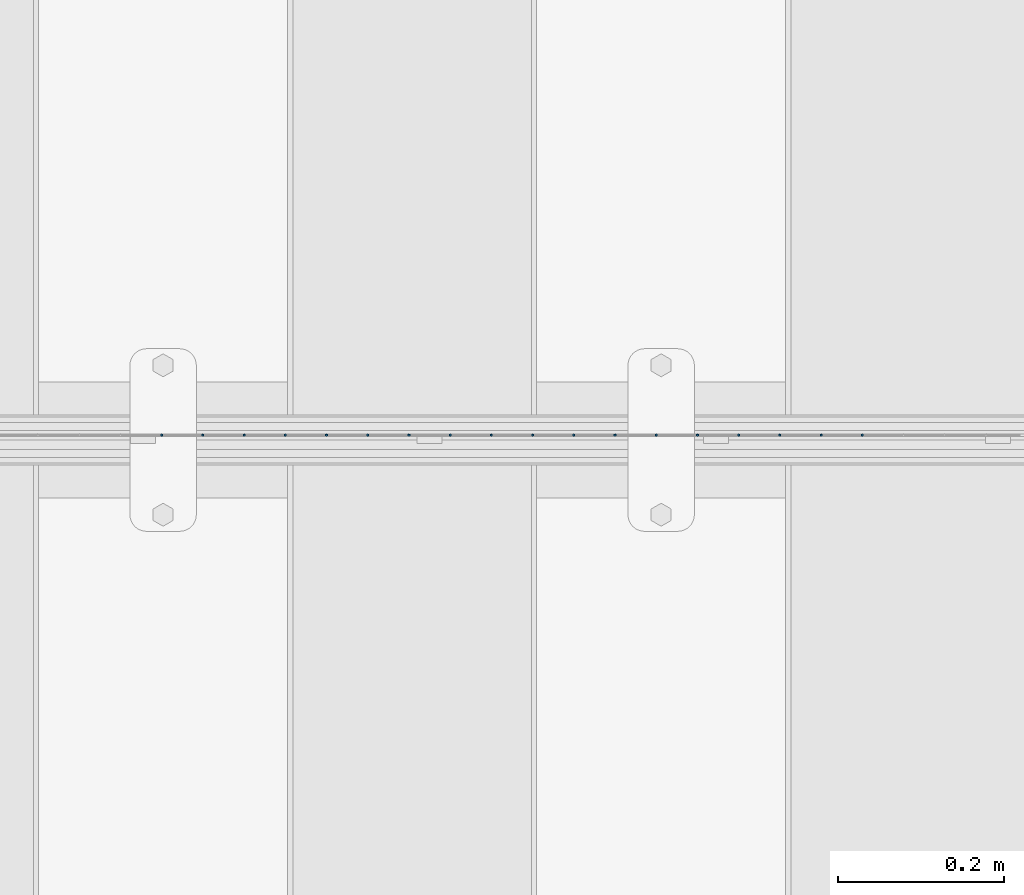
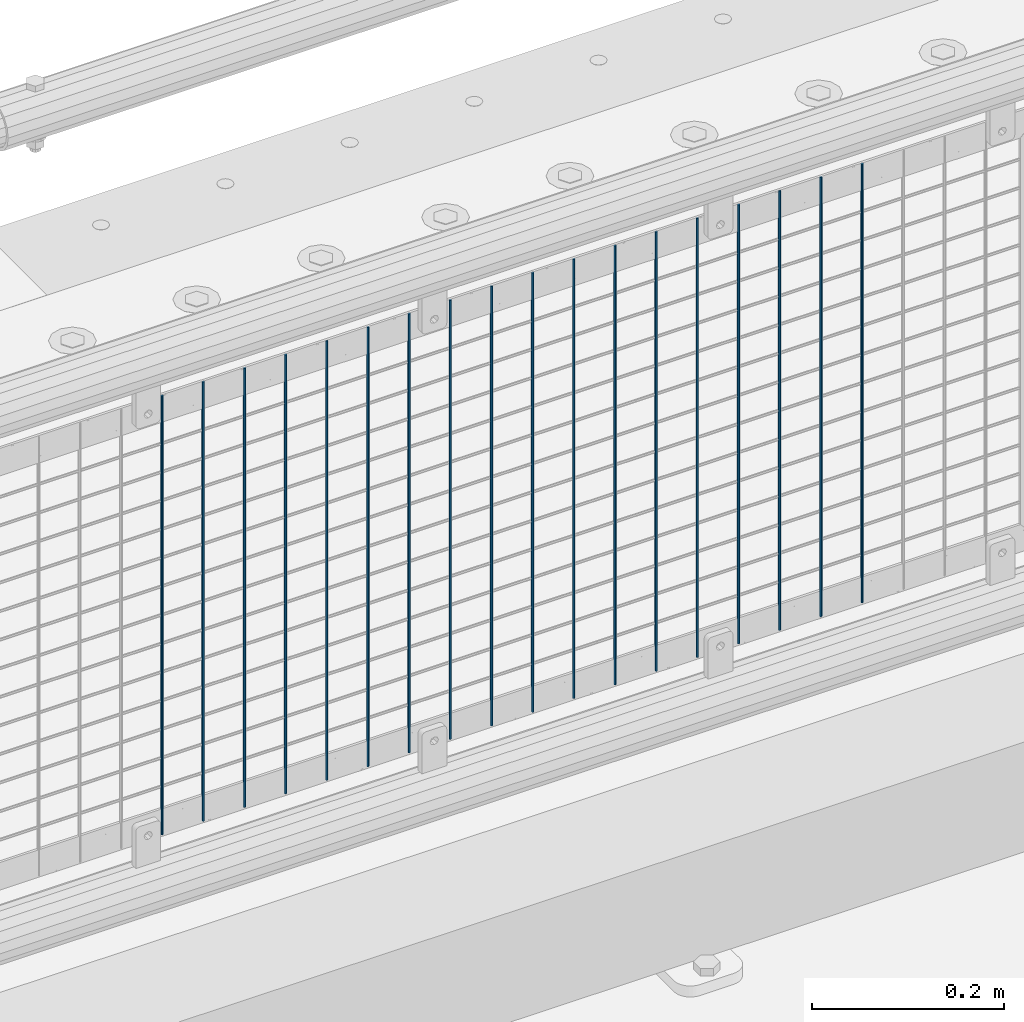
# One storey, part 87 of 247: 18 columns.
"""IFC2X3 building model written with IfcOpenShell, lengths in millimetres."""

import ifcopenshell
import ifcopenshell.guid

model = None  # the IFC model being written
_history = None  # IfcOwnerHistory: only IFC2X3 demands one
_inside = {}  # id of a spatial element -> (the spatial element, [elements in it])
_under = {}  # id of a project, library or spatial element -> (it, [spatial elements below it])
_declared = {}  # id of a project -> (the project, [libraries it declares])
_typed = {}  # id of a type object -> (the type object, [elements of that type])
_made_of = {}  # id of a material, layer set ... -> (it, [elements and type objects made of it])


def new_model(schema):
    """Start an empty IFC model of exactly this schema.

    Asked for "IFC4X3", IfcOpenShell would pick the latest addendum, in which some entities
    have other attributes; the version numbers below select the first issue.
    IFC2X3 requires an IfcOwnerHistory on every rooted entity: one is made here for all.
    """
    global model, _history
    if schema == "IFC4X3":
        model = ifcopenshell.file(schema_version=(4, 3, 0, 0))
    else:
        model = ifcopenshell.file(schema=schema)
    _inside.clear()
    _under.clear()
    _declared.clear()
    _typed.clear()
    _made_of.clear()
    _history = None
    if model.schema == "IFC2X3":
        org = make("IfcOrganization", Name="unknown")
        user = make(
            "IfcPersonAndOrganization",
            ThePerson=make("IfcPerson", FamilyName="unknown"),
            TheOrganization=org,
        )
        app = make(
            "IfcApplication",
            ApplicationDeveloper=org,
            Version="unknown",
            ApplicationFullName="unknown",
            ApplicationIdentifier="unknown",
        )
        _history = make(
            "IfcOwnerHistory",
            OwningUser=user,
            OwningApplication=app,
            ChangeAction="ADDED",
            CreationDate=0,
        )
    return model


def make(cls, **values):
    """One entity of the class cls with the attributes given. An attribute that is None is left unset."""
    return model.create_entity(
        cls, **{name: value for name, value in values.items() if value is not None}
    )


def rooted(cls, **values):
    """An entity with a GlobalId (a new one), such as an element, a storey or a relation."""
    return make(cls, GlobalId=ifcopenshell.guid.new(), OwnerHistory=_history, **values)


def si_unit(unit_type, name, prefix=None):
    """IfcSIUnit, for example si_unit("LENGTHUNIT", "METRE", prefix="MILLI")."""
    return make("IfcSIUnit", UnitType=unit_type, Prefix=prefix, Name=name)


def assignment(units):
    """IfcUnitAssignment: the units of a project."""
    return None if units is None else make("IfcUnitAssignment", Units=units)


def point(xyz):
    """IfcCartesianPoint."""
    return None if xyz is None else make("IfcCartesianPoint", Coordinates=xyz)


def direction(xyz):
    """IfcDirection."""
    return None if xyz is None else make("IfcDirection", DirectionRatios=xyz)


def frame(location, z_axis=None, x_axis=None):
    """IfcAxis2Placement3D, a coordinate frame: its origin and axes. An axis left out is left unset."""
    return make(
        "IfcAxis2Placement3D",
        Location=point(location),
        Axis=direction(z_axis),
        RefDirection=direction(x_axis),
    )


def origin_with_axes():
    """The frame at (0, 0, 0) with the z axis (0, 0, 1) and the x axis (1, 0, 0) written out."""
    return frame((0.0, 0.0, 0.0), z_axis=(0.0, 0.0, 1.0), x_axis=(1.0, 0.0, 0.0))


def place(relative_to, where):
    """IfcLocalPlacement: puts the frame where relative to a parent placement (None: the world)."""
    return make(
        "IfcLocalPlacement", PlacementRelTo=relative_to, RelativePlacement=where
    )


def context(
    kind, dimensions, precision=None, world=None, true_north=None, identifier=None
):
    """IfcGeometricRepresentationContext, for example the 3D "Model" context."""
    return make(
        "IfcGeometricRepresentationContext",
        ContextIdentifier=identifier,
        ContextType=kind,
        CoordinateSpaceDimension=dimensions,
        Precision=precision,
        WorldCoordinateSystem=world,
        TrueNorth=true_north,
    )


def subcontext(parent, identifier, kind, view, scale=None):
    """IfcGeometricRepresentationSubContext, for example "Body" below "Model"."""
    return make(
        "IfcGeometricRepresentationSubContext",
        ContextIdentifier=identifier,
        ContextType=kind,
        ParentContext=parent,
        TargetScale=scale,
        TargetView=view,
    )


def project(units=None, contexts=None):
    """IfcProject with its units and contexts."""
    return rooted(
        "IfcProject",
        Name="project",
        RepresentationContexts=contexts,
        UnitsInContext=assignment(units),
    )


def spatial(cls, under=None, at=None, **own):
    """A site, building, storey or space (cls), placed at a placement, below another one or the project."""
    s = rooted(cls, ObjectPlacement=at, **own)
    if under is not None:
        _under.setdefault(under.id(), (under, []))[1].append(s)
    return s


def faces_of(points, faces, orient=None, outer=None):
    """IfcFace entities. A face is a list of loops; a loop is a list of indices into points, from 0.

    orient and outer hold one flag for each loop. By default every Orientation is true, the
    first loop of a face is its IfcFaceOuterBound and the others are IfcFaceBound.
    """
    made = []
    for i, loops in enumerate(faces):
        bounds = []
        for j, loop in enumerate(loops):
            is_outer = j == 0 if outer is None else outer[i][j]
            bounds.append(
                make(
                    "IfcFaceOuterBound" if is_outer else "IfcFaceBound",
                    Bound=make("IfcPolyLoop", Polygon=[points[k] for k in loop]),
                    Orientation=True if orient is None else orient[i][j],
                )
            )
        made.append(make("IfcFace", Bounds=bounds))
    return made


def faceted_brep(points, faces, orient=None, outer=None, voids=None):
    """IfcFacetedBrep: a solid bounded by flat faces; with voids (closed shells), ...WithVoids."""
    shared = [point(p) for p in points]
    hull = make("IfcClosedShell", CfsFaces=faces_of(shared, faces, orient, outer))
    if voids is None:
        return make("IfcFacetedBrep", Outer=hull)
    return make(
        "IfcFacetedBrepWithVoids",
        Outer=hull,
        Voids=[
            make(cls, CfsFaces=faces_of(shared, fs, o, b)) for cls, fs, o, b in voids
        ],
    )


def shape(context_of_items, identifier, shape_type, items):
    """IfcShapeRepresentation: the items that make up one representation, for example the "Body"."""
    return make(
        "IfcShapeRepresentation",
        ContextOfItems=context_of_items,
        RepresentationIdentifier=identifier,
        RepresentationType=shape_type,
        Items=items,
    )


def material(Name=None, Category=None):
    """IfcMaterial."""
    return make("IfcMaterial", Name=Name, Category=Category)


def made_of(thing, what):
    """Note that an element or type object is made of a material, layer set ...; save() writes the relation."""
    if what is not None:
        _made_of.setdefault(what.id(), (what, []))[1].append(thing)
    return thing


def type_object(cls, material=None, **own):
    """A type object (cls), such as IfcWallType, which elements share."""
    return made_of(rooted(cls, **own), material)


def element(
    cls,
    number,
    at=None,
    inside=None,
    cuts=None,
    type_object=None,
    material=None,
    context=None,
    identifier="Body",
    shape_type=None,
    held_by="IfcProductDefinitionShape",
    body=None,
    shapes=None,
    **own,
):
    """One element of the class cls, such as IfcWall. Its Tag is "e" and its number.

    at: its placement. inside: the storey or other place that contains it. cuts: it is an
    opening in that element (IfcRelVoidsElement). A single representation is given by context,
    identifier, shape_type and body (its items); several are given by shapes. held_by: the class
    of the entity that holds the representations. save() writes the other relations.
    """
    e = rooted(cls, Tag="e%d" % number, ObjectPlacement=at, **own)
    if body is not None:
        shapes = [shape(context, identifier, shape_type, body)]
    if shapes is not None:
        e.Representation = make(held_by, Representations=shapes)
    if inside is not None:
        _inside.setdefault(inside.id(), (inside, []))[1].append(e)
    if cuts is not None:
        rooted(
            "IfcRelVoidsElement", RelatingBuildingElement=cuts, RelatedOpeningElement=e
        )
    if type_object is not None:
        _typed.setdefault(type_object.id(), (type_object, []))[1].append(e)
    return made_of(e, material)


def aggregate(whole, parts):
    """IfcRelAggregates: a whole, such as a stair, and the parts it consists of."""
    return rooted("IfcRelAggregates", RelatingObject=whole, RelatedObjects=parts)


def save(model, path):
    """Write the relations noted so far, then the file.

    IfcRelAggregates (storeys below a building ...), IfcRelContainedInSpatialStructure (elements
    in a storey), IfcRelDefinesByType, IfcRelAssociatesMaterial and IfcRelDeclares: one each for
    every whole, place, type object, material and project.
    """
    for whole, parts in _under.values():
        aggregate(whole, parts)
    for where, things in _inside.values():
        rooted(
            "IfcRelContainedInSpatialStructure",
            RelatedElements=things,
            RelatingStructure=where,
        )
    for kind, things in _typed.values():
        rooted("IfcRelDefinesByType", RelatedObjects=things, RelatingType=kind)
    for what, things in _made_of.values():
        rooted("IfcRelAssociatesMaterial", RelatedObjects=things, RelatingMaterial=what)
    for by, libraries in _declared.values():
        rooted("IfcRelDeclares", RelatingContext=by, RelatedDefinitions=libraries)
    model.write(path)


model = new_model("IFC2X3")

# Units and contexts
model_context = context("Model", 3, precision=1e-05, world=origin_with_axes())
body_context = subcontext(model_context, "Body", "Model", "MODEL_VIEW")
ifc_project = project(units=[si_unit("LENGTHUNIT", "METRE", prefix="MILLI"), si_unit("AREAUNIT", "SQUARE_METRE"), si_unit("VOLUMEUNIT", "CUBIC_METRE"), si_unit("MASSUNIT", "GRAM", prefix="KILO"), si_unit("TIMEUNIT", "SECOND"), si_unit("PLANEANGLEUNIT", "RADIAN"), si_unit("SOLIDANGLEUNIT", "STERADIAN"), si_unit("THERMODYNAMICTEMPERATUREUNIT", "DEGREE_CELSIUS"), si_unit("LUMINOUSINTENSITYUNIT", "LUMEN")], contexts=[model_context])

# Site, building, storey
site_placement = place(None, origin_with_axes())
site = spatial("IfcSite", under=ifc_project, at=site_placement, CompositionType="ELEMENT")
building_placement = place(site_placement, origin_with_axes())
building = spatial("IfcBuilding", under=site, at=building_placement, Name="Standard", CompositionType="ELEMENT")
storey_placement = place(building_placement, origin_with_axes())
storey = spatial("IfcBuildingStorey", under=building, at=storey_placement, Name="Undefined", CompositionType="ELEMENT", Elevation=0.0)

# Columns
ifc_material = material(Name="Misc_Undefined")
column_type = type_object("IfcColumnType", Name="D3", PredefinedType="NOTDEFINED")
for number, where, z_axis, x_axis in (
    (1, (9942.375, 7670.50000000001, 353.020000000003), (-1.0, 0.0, 0.0), (0.0, 0.0, 1.0)),
    (2, (9892.72, 7670.50000000001, 353.020000000003), (-1.0, 0.0, 0.0), (0.0, 0.0, 1.0)),
    (3, (9843.065, 7670.50000000001, 353.020000000003), (-1.0, 0.0, 0.0), (0.0, 0.0, 1.0)),
    (4, (9793.41, 7670.50000000001, 353.020000000003), (-1.0, 0.0, 0.0), (0.0, 0.0, 1.0)),
    (5, (9743.755, 7670.50000000001, 353.020000000003), (-1.0, 0.0, 0.0), (0.0, 0.0, 1.0)),
    (6, (9694.1, 7670.50000000001, 353.020000000003), (-1.0, 0.0, 0.0), (0.0, 0.0, 1.0)),
    (7, (9644.445, 7670.50000000001, 353.020000000003), (-1.0, 0.0, 0.0), (0.0, 0.0, 1.0)),
    (8, (9594.79, 7670.50000000001, 353.020000000003), (-1.0, 0.0, 0.0), (0.0, 0.0, 1.0)),
    (9, (9545.135, 7670.50000000001, 353.020000000003), (-1.0, 0.0, 0.0), (0.0, 0.0, 1.0)),
    (10, (9495.48, 7670.50000000001, 353.020000000003), (-1.0, 0.0, 0.0), (0.0, 0.0, 1.0)),
    (11, (9445.825, 7670.50000000001, 353.020000000003), (-1.0, 0.0, 0.0), (0.0, 0.0, 1.0)),
    (12, (9396.17, 7670.50000000001, 353.020000000003), (-1.0, 0.0, 0.0), (0.0, 0.0, 1.0)),
    (13, (9346.515, 7670.50000000001, 353.020000000003), (-1.0, 0.0, 0.0), (0.0, 0.0, 1.0)),
    (14, (9296.86, 7670.50000000001, 353.020000000003), (-1.0, 0.0, 0.0), (0.0, 0.0, 1.0)),
    (15, (9247.205, 7670.50000000001, 353.020000000003), (-1.0, 0.0, 0.0), (0.0, 0.0, 1.0)),
    (16, (9197.55, 7670.5, 353.020000000003), (-1.0, 0.0, 0.0), (0.0, 0.0, 1.0)),
    (17, (9147.895, 7670.5, 353.020000000003), (-1.0, 0.0, 0.0), (0.0, 0.0, 1.0)),
    (18, (9098.24, 7670.5, 353.020000000003), (-1.0, 0.0, 0.0), (0.0, 0.0, 1.0)),
):
    element("IfcColumn", number, at=place(storey_placement, frame(where, z_axis=z_axis, x_axis=x_axis)), inside=storey, type_object=column_type, material=ifc_material, ObjectType="D3", context=body_context, shape_type="Brep", body=[
        faceted_brep([(1.81898940354586e-12, -1.5, -5.6843418860808e-14), (0.0, -0.75, -1.29903810567703), (560.0, -0.75, -1.29903810567703), (560.0, -1.5, 0.0), (0.0, 0.75, -1.29903810567703), (560.0, 0.75, -1.29903810567703), (1.81898940354586e-12, 1.5, -5.6843418860808e-14), (560.0, 1.5, 0.0), (0.0, 0.75, 1.29903810567703), (560.0, 0.75, 1.29903810567703), (0.0, -0.75, 1.29903810567703), (560.0, -0.75, 1.29903810567703)], [[[0, 1, 2, 3]], [[1, 4, 5, 2]], [[4, 6, 7, 5]], [[6, 8, 9, 7]], [[8, 10, 11, 9]], [[10, 0, 3, 11]], [[5, 7, 9, 11, 3, 2]], [[10, 8, 6, 4, 1, 0]]]),
    ])

save(model, "model.ifc")
